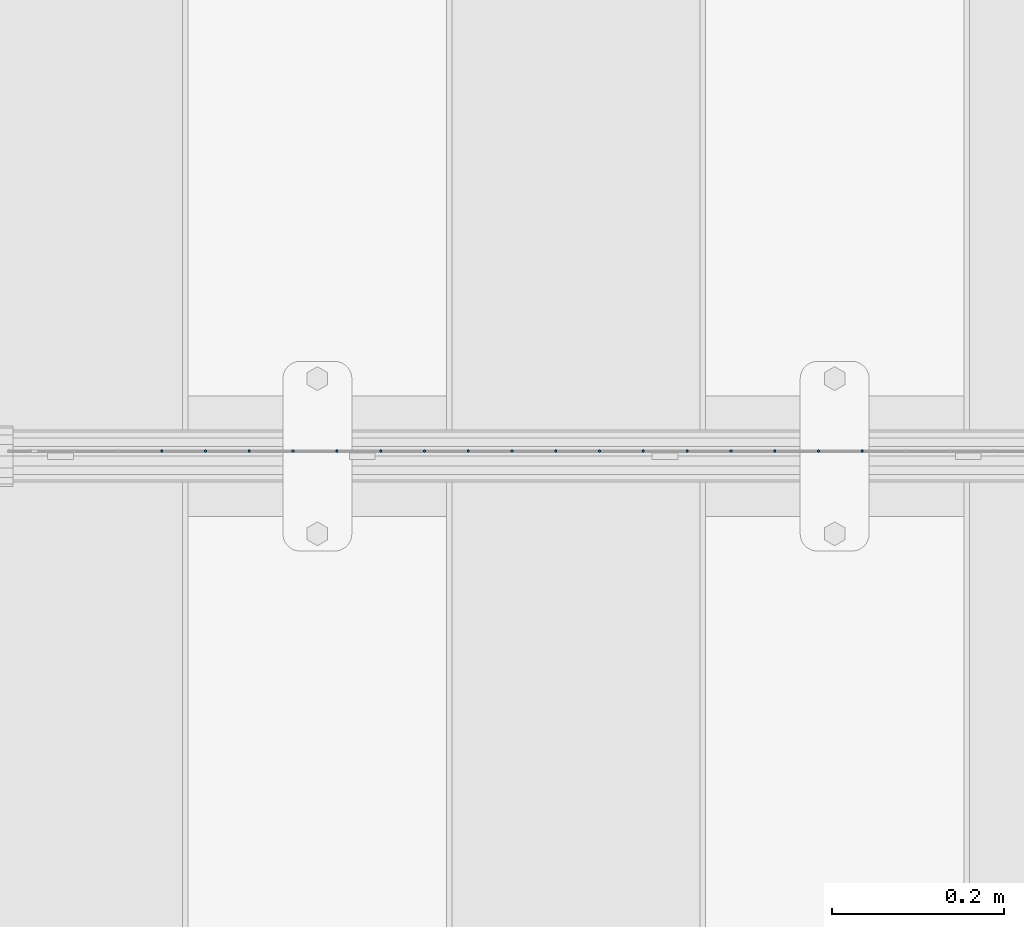
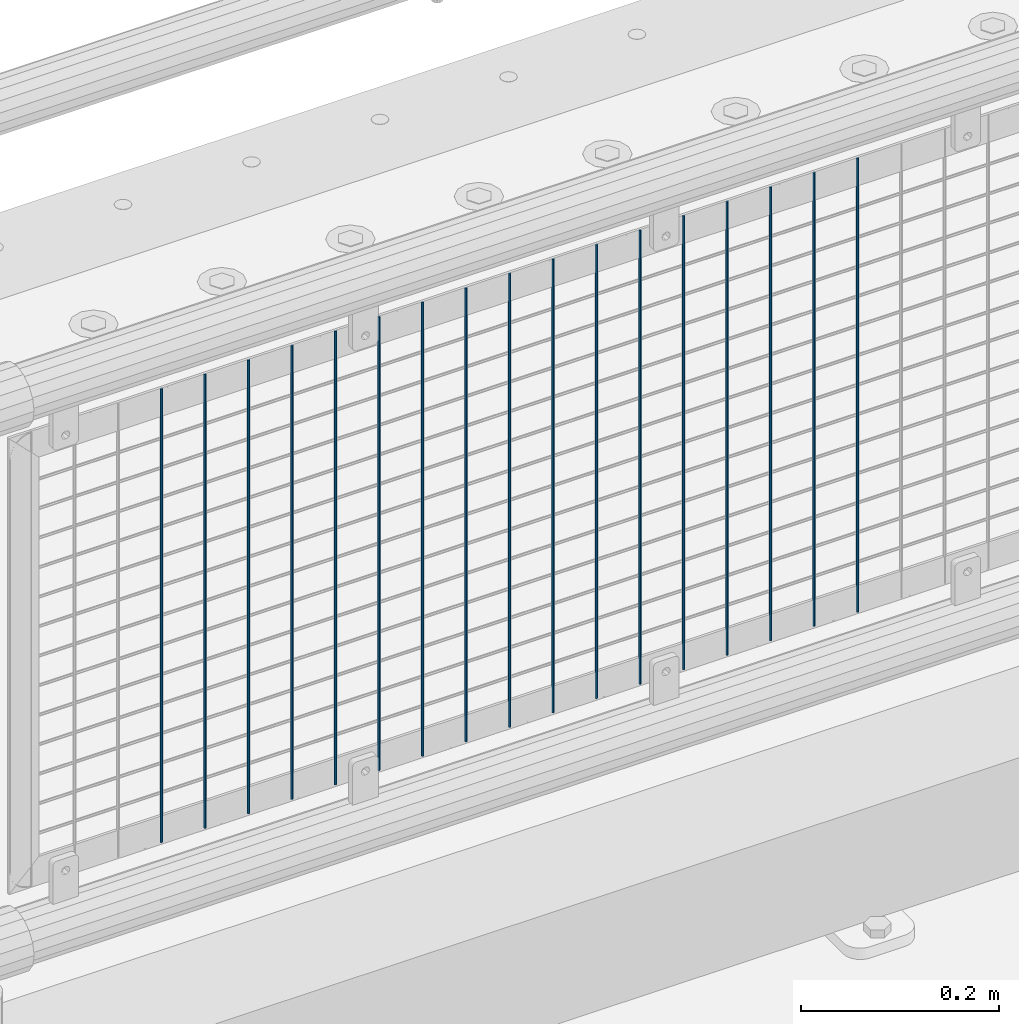
# One storey, part 70 of 242: 17 columns.
"""IFC2X3 building model written with IfcOpenShell, lengths in millimetres."""

import ifcopenshell
import ifcopenshell.guid

model = None  # the IFC model being written
_history = None  # IfcOwnerHistory: only IFC2X3 demands one
_inside = {}  # id of a spatial element -> (the spatial element, [elements in it])
_under = {}  # id of a project, library or spatial element -> (it, [spatial elements below it])
_declared = {}  # id of a project -> (the project, [libraries it declares])
_typed = {}  # id of a type object -> (the type object, [elements of that type])
_made_of = {}  # id of a material, layer set ... -> (it, [elements and type objects made of it])


def new_model(schema):
    """Start an empty IFC model of exactly this schema.

    Asked for "IFC4X3", IfcOpenShell would pick the latest addendum, in which some entities
    have other attributes; the version numbers below select the first issue.
    IFC2X3 requires an IfcOwnerHistory on every rooted entity: one is made here for all.
    """
    global model, _history
    if schema == "IFC4X3":
        model = ifcopenshell.file(schema_version=(4, 3, 0, 0))
    else:
        model = ifcopenshell.file(schema=schema)
    _inside.clear()
    _under.clear()
    _declared.clear()
    _typed.clear()
    _made_of.clear()
    _history = None
    if model.schema == "IFC2X3":
        org = make("IfcOrganization", Name="unknown")
        user = make(
            "IfcPersonAndOrganization",
            ThePerson=make("IfcPerson", FamilyName="unknown"),
            TheOrganization=org,
        )
        app = make(
            "IfcApplication",
            ApplicationDeveloper=org,
            Version="unknown",
            ApplicationFullName="unknown",
            ApplicationIdentifier="unknown",
        )
        _history = make(
            "IfcOwnerHistory",
            OwningUser=user,
            OwningApplication=app,
            ChangeAction="ADDED",
            CreationDate=0,
        )
    return model


def make(cls, **values):
    """One entity of the class cls with the attributes given. An attribute that is None is left unset."""
    return model.create_entity(
        cls, **{name: value for name, value in values.items() if value is not None}
    )


def rooted(cls, **values):
    """An entity with a GlobalId (a new one), such as an element, a storey or a relation."""
    return make(cls, GlobalId=ifcopenshell.guid.new(), OwnerHistory=_history, **values)


def si_unit(unit_type, name, prefix=None):
    """IfcSIUnit, for example si_unit("LENGTHUNIT", "METRE", prefix="MILLI")."""
    return make("IfcSIUnit", UnitType=unit_type, Prefix=prefix, Name=name)


def assignment(units):
    """IfcUnitAssignment: the units of a project."""
    return None if units is None else make("IfcUnitAssignment", Units=units)


def point(xyz):
    """IfcCartesianPoint."""
    return None if xyz is None else make("IfcCartesianPoint", Coordinates=xyz)


def direction(xyz):
    """IfcDirection."""
    return None if xyz is None else make("IfcDirection", DirectionRatios=xyz)


def frame(location, z_axis=None, x_axis=None):
    """IfcAxis2Placement3D, a coordinate frame: its origin and axes. An axis left out is left unset."""
    return make(
        "IfcAxis2Placement3D",
        Location=point(location),
        Axis=direction(z_axis),
        RefDirection=direction(x_axis),
    )


def origin_with_axes():
    """The frame at (0, 0, 0) with the z axis (0, 0, 1) and the x axis (1, 0, 0) written out."""
    return frame((0.0, 0.0, 0.0), z_axis=(0.0, 0.0, 1.0), x_axis=(1.0, 0.0, 0.0))


def place(relative_to, where):
    """IfcLocalPlacement: puts the frame where relative to a parent placement (None: the world)."""
    return make(
        "IfcLocalPlacement", PlacementRelTo=relative_to, RelativePlacement=where
    )


def context(
    kind, dimensions, precision=None, world=None, true_north=None, identifier=None
):
    """IfcGeometricRepresentationContext, for example the 3D "Model" context."""
    return make(
        "IfcGeometricRepresentationContext",
        ContextIdentifier=identifier,
        ContextType=kind,
        CoordinateSpaceDimension=dimensions,
        Precision=precision,
        WorldCoordinateSystem=world,
        TrueNorth=true_north,
    )


def subcontext(parent, identifier, kind, view, scale=None):
    """IfcGeometricRepresentationSubContext, for example "Body" below "Model"."""
    return make(
        "IfcGeometricRepresentationSubContext",
        ContextIdentifier=identifier,
        ContextType=kind,
        ParentContext=parent,
        TargetScale=scale,
        TargetView=view,
    )


def project(units=None, contexts=None):
    """IfcProject with its units and contexts."""
    return rooted(
        "IfcProject",
        Name="project",
        RepresentationContexts=contexts,
        UnitsInContext=assignment(units),
    )


def spatial(cls, under=None, at=None, **own):
    """A site, building, storey or space (cls), placed at a placement, below another one or the project."""
    s = rooted(cls, ObjectPlacement=at, **own)
    if under is not None:
        _under.setdefault(under.id(), (under, []))[1].append(s)
    return s


def faces_of(points, faces, orient=None, outer=None):
    """IfcFace entities. A face is a list of loops; a loop is a list of indices into points, from 0.

    orient and outer hold one flag for each loop. By default every Orientation is true, the
    first loop of a face is its IfcFaceOuterBound and the others are IfcFaceBound.
    """
    made = []
    for i, loops in enumerate(faces):
        bounds = []
        for j, loop in enumerate(loops):
            is_outer = j == 0 if outer is None else outer[i][j]
            bounds.append(
                make(
                    "IfcFaceOuterBound" if is_outer else "IfcFaceBound",
                    Bound=make("IfcPolyLoop", Polygon=[points[k] for k in loop]),
                    Orientation=True if orient is None else orient[i][j],
                )
            )
        made.append(make("IfcFace", Bounds=bounds))
    return made


def faceted_brep(points, faces, orient=None, outer=None, voids=None):
    """IfcFacetedBrep: a solid bounded by flat faces; with voids (closed shells), ...WithVoids."""
    shared = [point(p) for p in points]
    hull = make("IfcClosedShell", CfsFaces=faces_of(shared, faces, orient, outer))
    if voids is None:
        return make("IfcFacetedBrep", Outer=hull)
    return make(
        "IfcFacetedBrepWithVoids",
        Outer=hull,
        Voids=[
            make(cls, CfsFaces=faces_of(shared, fs, o, b)) for cls, fs, o, b in voids
        ],
    )


def shape(context_of_items, identifier, shape_type, items):
    """IfcShapeRepresentation: the items that make up one representation, for example the "Body"."""
    return make(
        "IfcShapeRepresentation",
        ContextOfItems=context_of_items,
        RepresentationIdentifier=identifier,
        RepresentationType=shape_type,
        Items=items,
    )


def material(Name=None, Category=None):
    """IfcMaterial."""
    return make("IfcMaterial", Name=Name, Category=Category)


def made_of(thing, what):
    """Note that an element or type object is made of a material, layer set ...; save() writes the relation."""
    if what is not None:
        _made_of.setdefault(what.id(), (what, []))[1].append(thing)
    return thing


def type_object(cls, material=None, **own):
    """A type object (cls), such as IfcWallType, which elements share."""
    return made_of(rooted(cls, **own), material)


def element(
    cls,
    number,
    at=None,
    inside=None,
    cuts=None,
    type_object=None,
    material=None,
    context=None,
    identifier="Body",
    shape_type=None,
    held_by="IfcProductDefinitionShape",
    body=None,
    shapes=None,
    **own,
):
    """One element of the class cls, such as IfcWall. Its Tag is "e" and its number.

    at: its placement. inside: the storey or other place that contains it. cuts: it is an
    opening in that element (IfcRelVoidsElement). A single representation is given by context,
    identifier, shape_type and body (its items); several are given by shapes. held_by: the class
    of the entity that holds the representations. save() writes the other relations.
    """
    e = rooted(cls, Tag="e%d" % number, ObjectPlacement=at, **own)
    if body is not None:
        shapes = [shape(context, identifier, shape_type, body)]
    if shapes is not None:
        e.Representation = make(held_by, Representations=shapes)
    if inside is not None:
        _inside.setdefault(inside.id(), (inside, []))[1].append(e)
    if cuts is not None:
        rooted(
            "IfcRelVoidsElement", RelatingBuildingElement=cuts, RelatedOpeningElement=e
        )
    if type_object is not None:
        _typed.setdefault(type_object.id(), (type_object, []))[1].append(e)
    return made_of(e, material)


def aggregate(whole, parts):
    """IfcRelAggregates: a whole, such as a stair, and the parts it consists of."""
    return rooted("IfcRelAggregates", RelatingObject=whole, RelatedObjects=parts)


def save(model, path):
    """Write the relations noted so far, then the file.

    IfcRelAggregates (storeys below a building ...), IfcRelContainedInSpatialStructure (elements
    in a storey), IfcRelDefinesByType, IfcRelAssociatesMaterial and IfcRelDeclares: one each for
    every whole, place, type object, material and project.
    """
    for whole, parts in _under.values():
        aggregate(whole, parts)
    for where, things in _inside.values():
        rooted(
            "IfcRelContainedInSpatialStructure",
            RelatedElements=things,
            RelatingStructure=where,
        )
    for kind, things in _typed.values():
        rooted("IfcRelDefinesByType", RelatedObjects=things, RelatingType=kind)
    for what, things in _made_of.values():
        rooted("IfcRelAssociatesMaterial", RelatedObjects=things, RelatingMaterial=what)
    for by, libraries in _declared.values():
        rooted("IfcRelDeclares", RelatingContext=by, RelatedDefinitions=libraries)
    model.write(path)


model = new_model("IFC2X3")

# Units and contexts
model_context = context("Model", 3, precision=1e-05, world=origin_with_axes())
body_context = subcontext(model_context, "Body", "Model", "MODEL_VIEW")
ifc_project = project(units=[si_unit("LENGTHUNIT", "METRE", prefix="MILLI"), si_unit("AREAUNIT", "SQUARE_METRE"), si_unit("VOLUMEUNIT", "CUBIC_METRE"), si_unit("MASSUNIT", "GRAM", prefix="KILO"), si_unit("TIMEUNIT", "SECOND"), si_unit("PLANEANGLEUNIT", "RADIAN"), si_unit("SOLIDANGLEUNIT", "STERADIAN"), si_unit("THERMODYNAMICTEMPERATUREUNIT", "DEGREE_CELSIUS"), si_unit("LUMINOUSINTENSITYUNIT", "LUMEN")], contexts=[model_context])

# Site, building, storey
site_placement = place(None, origin_with_axes())
site = spatial("IfcSite", under=ifc_project, at=site_placement, CompositionType="ELEMENT")
building_placement = place(site_placement, origin_with_axes())
building = spatial("IfcBuilding", under=site, at=building_placement, Name="Standard", CompositionType="ELEMENT")
storey_placement = place(building_placement, origin_with_axes())
storey = spatial("IfcBuildingStorey", under=building, at=storey_placement, Name="Undefined", CompositionType="ELEMENT", Elevation=0.0)

# Columns
ifc_material = material(Name="Misc_Undefined")
column_type = type_object("IfcColumnType", Name="D3", PredefinedType="NOTDEFINED")
for number, where, z_axis, x_axis in (
    (1, (-37517.933, -19329.5, 353.02), (-1.0, 0.0, 0.0), (0.0, 0.0, 1.0)),
    (2, (-37568.726, -19329.5, 353.02), (-1.0, 0.0, 0.0), (0.0, 0.0, 1.0)),
    (3, (-37619.519, -19329.5, 353.02), (-1.0, 0.0, 0.0), (0.0, 0.0, 1.0)),
    (4, (-37670.312, -19329.5, 353.02), (-1.0, 0.0, 0.0), (0.0, 0.0, 1.0)),
    (5, (-37721.105, -19329.5, 353.02), (-1.0, 0.0, 0.0), (0.0, 0.0, 1.0)),
    (6, (-37771.898, -19329.5, 353.02), (-1.0, 0.0, 0.0), (0.0, 0.0, 1.0)),
    (7, (-37822.691, -19329.5, 353.02), (-1.0, 0.0, 0.0), (0.0, 0.0, 1.0)),
    (8, (-37873.484, -19329.5, 353.02), (-1.0, 0.0, 0.0), (0.0, 0.0, 1.0)),
    (9, (-37924.277, -19329.5, 353.02), (-1.0, 0.0, 0.0), (0.0, 0.0, 1.0)),
    (10, (-37975.07, -19329.5, 353.02), (-1.0, 0.0, 0.0), (0.0, 0.0, 1.0)),
    (11, (-38025.863, -19329.5, 353.02), (-1.0, 0.0, 0.0), (0.0, 0.0, 1.0)),
    (12, (-38076.656, -19329.5, 353.02), (-1.0, 0.0, 0.0), (0.0, 0.0, 1.0)),
    (13, (-38127.449, -19329.5, 353.02), (-1.0, 0.0, 0.0), (0.0, 0.0, 1.0)),
    (14, (-38178.242, -19329.5, 353.02), (-1.0, 0.0, 0.0), (0.0, 0.0, 1.0)),
    (15, (-38229.035, -19329.5, 353.02), (-1.0, 0.0, 0.0), (0.0, 0.0, 1.0)),
    (16, (-38279.828, -19329.5, 353.02), (-1.0, 0.0, 0.0), (0.0, 0.0, 1.0)),
    (17, (-38330.621, -19329.5, 353.02), (-1.0, 0.0, 0.0), (0.0, 0.0, 1.0)),
):
    element("IfcColumn", number, at=place(storey_placement, frame(where, z_axis=z_axis, x_axis=x_axis)), inside=storey, type_object=column_type, material=ifc_material, ObjectType="D3", context=body_context, shape_type="Brep", body=[
        faceted_brep([(0.0, -1.50000000000364, 0.0), (-3.63797880709171e-12, -0.750000000003638, -1.29903810567669), (560.0, -0.75, -1.29903810567703), (560.0, -1.5, 0.0), (0.0, 0.749999999996362, -1.29903810567669), (560.0, 0.75, -1.29903810567703), (-3.63797880709171e-12, 1.49999999999636, 0.0), (560.0, 1.5, 0.0), (0.0, 0.749999999996362, 1.29903810567669), (560.0, 0.75, 1.29903810567703), (-3.63797880709171e-12, -0.750000000003638, 1.29903810567669), (560.0, -0.75, 1.29903810567703)], [[[0, 1, 2, 3]], [[1, 4, 5, 2]], [[4, 6, 7, 5]], [[6, 8, 9, 7]], [[8, 10, 11, 9]], [[10, 0, 3, 11]], [[5, 7, 9, 11, 3, 2]], [[10, 8, 6, 4, 1, 0]]]),
    ])

save(model, "model.ifc")
